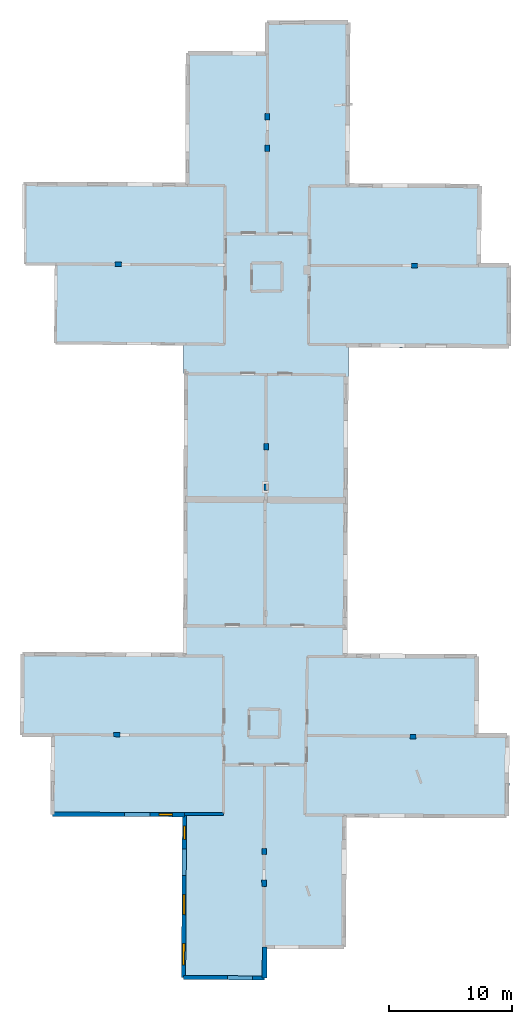
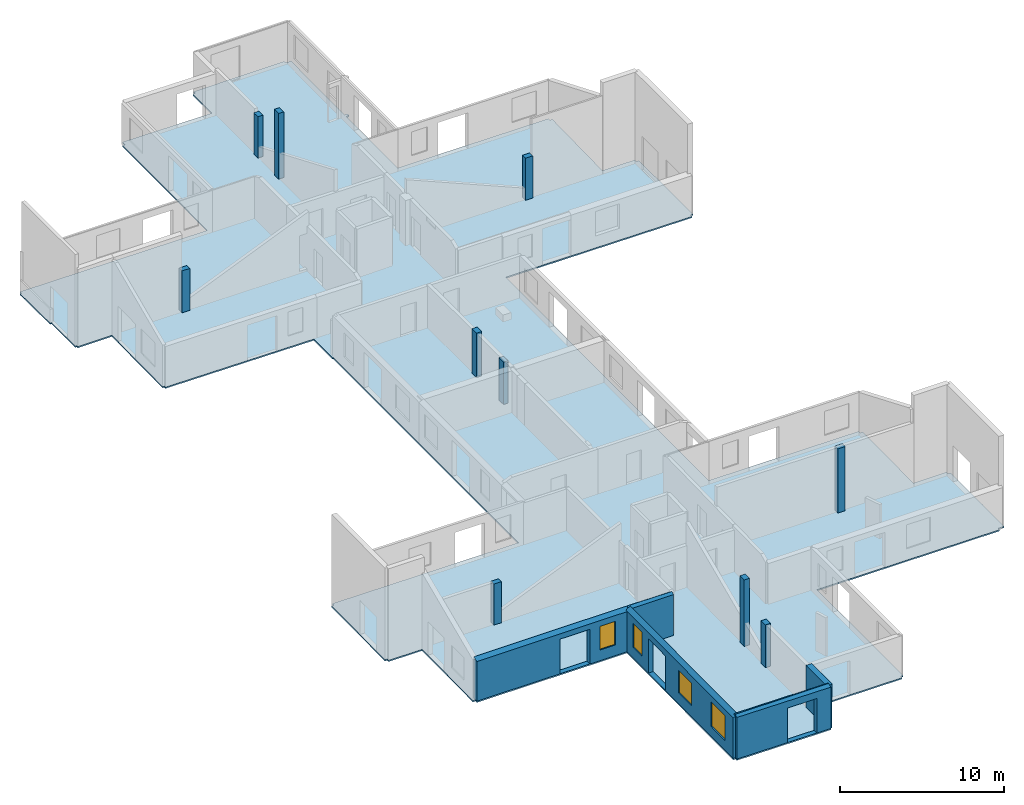
# One storey, part 1 of 10: 10 columns, 5 walls, 4 windows, 1 slab, 7 openings.
"""IFC2X3 building model written with IfcOpenShell, lengths in metres."""

from ifc_helpers import new_model, entity, si_unit, converted_unit, derived_unit, direction, frame, frame_2d, origin, origin_2d_with_axis, place, context, subcontext, project, spatial, polyline, rectangle, outline, extrude, clip, halfspace, source, transform, mapped, material, layer, layer_set, layer_usage, type_object, type_shapes, element, fill, save


model = new_model("IFC2X3")

# Units and contexts
model_context = context("Model", 3, precision=1e-05, world=origin(), true_north=direction((0.0, 1.0)))
body_context = subcontext(model_context, "Body", "Model", "MODEL_VIEW")
ifc_project = project(units=[si_unit("LENGTHUNIT", "METRE"), si_unit("AREAUNIT", "SQUARE_METRE"), si_unit("VOLUMEUNIT", "CUBIC_METRE"), converted_unit("PLANEANGLEUNIT", "DEGREE", entity("IfcRatioMeasure", 0.0174532925199433), si_unit("PLANEANGLEUNIT", "RADIAN"), dimensions=[0, 0, 0, 0, 0, 0, 0]), si_unit("MASSUNIT", "GRAM", prefix="KILO"), derived_unit("MASSDENSITYUNIT", [(si_unit("MASSUNIT", "GRAM", prefix="KILO"), 1), (si_unit("LENGTHUNIT", "METRE"), -3)]), derived_unit("MOMENTOFINERTIAUNIT", [(si_unit("LENGTHUNIT", "METRE"), 4)]), si_unit("TIMEUNIT", "SECOND"), si_unit("FREQUENCYUNIT", "HERTZ"), si_unit("THERMODYNAMICTEMPERATUREUNIT", "DEGREE_CELSIUS"), derived_unit("THERMALTRANSMITTANCEUNIT", [(si_unit("MASSUNIT", "GRAM", prefix="KILO"), 1), (si_unit("THERMODYNAMICTEMPERATUREUNIT", "KELVIN"), -1), (si_unit("TIMEUNIT", "SECOND"), -3)]), derived_unit("VOLUMETRICFLOWRATEUNIT", [(si_unit("LENGTHUNIT", "METRE"), 3), (si_unit("TIMEUNIT", "SECOND"), -1)]), si_unit("ELECTRICCURRENTUNIT", "AMPERE"), si_unit("ELECTRICVOLTAGEUNIT", "VOLT"), si_unit("POWERUNIT", "WATT"), si_unit("FORCEUNIT", "NEWTON", prefix="KILO"), si_unit("ILLUMINANCEUNIT", "LUX"), si_unit("LUMINOUSFLUXUNIT", "LUMEN"), si_unit("LUMINOUSINTENSITYUNIT", "CANDELA"), derived_unit("USERDEFINED", [(si_unit("MASSUNIT", "GRAM", prefix="KILO"), -1), (si_unit("LENGTHUNIT", "METRE"), -2), (si_unit("TIMEUNIT", "SECOND"), 3), (si_unit("LUMINOUSFLUXUNIT", "LUMEN"), 1)]), derived_unit("LINEARVELOCITYUNIT", [(si_unit("LENGTHUNIT", "METRE"), 1), (si_unit("TIMEUNIT", "SECOND"), -1)]), si_unit("PRESSUREUNIT", "PASCAL"), derived_unit("USERDEFINED", [(si_unit("LENGTHUNIT", "METRE"), -2), (si_unit("MASSUNIT", "GRAM", prefix="KILO"), 1), (si_unit("TIMEUNIT", "SECOND"), -2)]), derived_unit("LINEARFORCEUNIT", [(si_unit("MASSUNIT", "GRAM", prefix="KILO"), 1), (si_unit("LENGTHUNIT", "METRE"), 1), (si_unit("TIMEUNIT", "SECOND"), -2), (si_unit("LENGTHUNIT", "METRE"), -1)]), derived_unit("PLANARFORCEUNIT", [(si_unit("MASSUNIT", "GRAM", prefix="KILO"), 1), (si_unit("LENGTHUNIT", "METRE"), 1), (si_unit("TIMEUNIT", "SECOND"), -2), (si_unit("LENGTHUNIT", "METRE"), -2)])], contexts=[model_context])

# Site, building, storey
placement = place(None, origin())
site = spatial("IfcSite", under=ifc_project, at=placement, CompositionType="ELEMENT")
building = spatial("IfcBuilding", under=site, at=placement, CompositionType="ELEMENT")
storey_placement = place(placement, frame((0.0, 0.0, 15.2695512771606)))
storey = spatial("IfcBuildingStorey", under=building, at=storey_placement, Name="Level 6", CompositionType="ELEMENT", Elevation=15.2695512771606)

# Columns
ifc_material_1 = material()
column_type_1 = type_object("IfcColumnType", Name="Rectangular Column:555 x 310mm", PredefinedType="COLUMN", material=ifc_material_1)
shared_shape_1 = source(origin(), body_context, "Body", "SweptSolid", [
    extrude(rectangle(XDim=0.554955618167444, YDim=0.310000002384186, at=origin_2d_with_axis()), frame((0.0, 0.0, 0.0), z_axis=(0.0, 0.0, 1.0), x_axis=(0.0, -1.0, 0.0)), (0.0, 0.0, 1.0), 3.14399909973145),
])
type_shapes(column_type_1, [shared_shape_1])
column_1_placement = place(placement, frame((6.28059962989122, 39.5834904717086, 15.2700004577637), z_axis=(0.0, 0.0, 1.0), x_axis=(0.999998038736103, 0.00198053627772667, 0.0)))
element("IfcColumn", 1, at=column_1_placement, inside=storey, type_object=column_type_1, Name="Rectangular Column:555 x 310mm", ObjectType="Rectangular Column:555 x 310mm", context=body_context, shape_type="MappedRepresentation", body=[
    mapped(shared_shape_1, transform((0.0, 0.0, 0.0), scale=1.0)),
])
column_type_2 = type_object("IfcColumnType", Name="Rectangular Column:496 x 360mm", PredefinedType="COLUMN", material=ifc_material_1)
shared_shape_2 = source(origin(), body_context, "Body", "SweptSolid", [
    extrude(rectangle(XDim=0.495687838627537, YDim=0.360000014305115, at=origin_2d_with_axis()), frame((0.0, 0.0, 0.0), z_axis=(0.0, 0.0, 1.0), x_axis=(0.0, -1.0, 0.0)), (0.0, 0.0, 1.0), 3.07500076293945),
])
type_shapes(column_type_2, [shared_shape_2])
column_2_placement = place(placement, frame((6.42300283798488, 69.6784577781805, 15.2730007171631), z_axis=(0.0, 0.0, 1.0), x_axis=(-0.999987741803725, -0.00495138791516025, 0.0)))
element("IfcColumn", 2, at=column_2_placement, inside=storey, type_object=column_type_2, Name="Rectangular Column:496 x 360mm", ObjectType="Rectangular Column:496 x 360mm", context=body_context, shape_type="MappedRepresentation", body=[
    mapped(shared_shape_2, transform((0.0, 0.0, 0.0), scale=1.0)),
])
column_type_3 = type_object("IfcColumnType", Name="Rectangular Column:541 x 360mm", PredefinedType="COLUMN", material=ifc_material_1)
shared_shape_3 = source(origin(), body_context, "Body", "SweptSolid", [
    extrude(rectangle(XDim=0.540847853740699, YDim=0.360000014305115, at=origin_2d_with_axis()), frame((0.0, 0.0, 0.0), z_axis=(0.0, 0.0, 1.0), x_axis=(0.0, -1.0, 0.0)), (0.0, 0.0, 1.0), 3.30699920654297),
])
type_shapes(column_type_3, [shared_shape_3])
column_3_placement = place(placement, frame((6.31458798521526, 42.8700176879794, 15.2700004577637), z_axis=(0.0, 0.0, 1.0), x_axis=(-0.999999860578549, -0.000528055756389902, 0.0)))
element("IfcColumn", 3, at=column_3_placement, inside=storey, type_object=column_type_3, Name="Rectangular Column:541 x 360mm", ObjectType="Rectangular Column:541 x 360mm", context=body_context, shape_type="MappedRepresentation", body=[
    mapped(shared_shape_3, transform((0.0, 0.0, 0.0), scale=1.0)),
])
column_type_4 = type_object("IfcColumnType", Name="Rectangular Column:520 x 360mm", PredefinedType="COLUMN", material=ifc_material_1)
shared_shape_4 = source(origin(), body_context, "Body", "SweptSolid", [
    extrude(rectangle(XDim=0.519999906082088, YDim=0.360000014305115, at=origin_2d_with_axis()), frame((0.0, 0.0, 0.0), z_axis=(0.0, 0.0, 1.0), x_axis=(0.0, -1.0, 0.0)), (0.0, 0.0, 1.0), 3.04999923706055),
])
type_shapes(column_type_4, [shared_shape_4])
column_4_placement = place(placement, frame((-5.82657999178579, 19.4923216225972, 15.2700004577637), z_axis=(0.0, 0.0, 1.0), x_axis=(-0.0108205395384515, -0.999941456248363, 0.0)))
element("IfcColumn", 4, at=column_4_placement, inside=storey, type_object=column_type_4, Name="Rectangular Column:520 x 360mm", ObjectType="Rectangular Column:520 x 360mm", context=body_context, shape_type="MappedRepresentation", body=[
    mapped(shared_shape_4, transform((0.0, 0.0, 0.0), scale=1.0)),
])
column_type_5 = type_object("IfcColumnType", Name="Rectangular Column:530 x 370mm", PredefinedType="COLUMN", material=ifc_material_1)
shared_shape_5 = source(origin(), body_context, "Body", "SweptSolid", [
    extrude(rectangle(XDim=0.529999889638574, YDim=0.370000004768372, at=origin_2d_with_axis()), frame((0.0, 0.0, 0.0), z_axis=(0.0, 0.0, 1.0), x_axis=(0.0, -1.0, 0.0)), (0.0, 0.0, 1.0), 3.18000030517578),
])
type_shapes(column_type_5, [shared_shape_5])
column_5_placement = place(placement, frame((6.14692479751303, 7.39468000555512, 15.2709999084473), z_axis=(0.0, 0.0, 1.0), x_axis=(-0.999978111767537, -0.00661634233021978, 0.0)))
element("IfcColumn", 5, at=column_5_placement, inside=storey, type_object=column_type_5, Name="Rectangular Column:530 x 370mm", ObjectType="Rectangular Column:530 x 370mm", context=body_context, shape_type="MappedRepresentation", body=[
    mapped(shared_shape_5, transform((0.0, 0.0, 0.0), scale=1.0)),
])
column_type_6 = type_object("IfcColumnType", Name="Rectangular Column:547 x 360mm", PredefinedType="COLUMN", material=ifc_material_1)
shared_shape_6 = source(origin(), body_context, "Body", "SweptSolid", [
    extrude(rectangle(XDim=0.546929120389239, YDim=0.360000014305115, at=origin_2d_with_axis()), frame((0.0, 0.0, 0.0), z_axis=(0.0, 0.0, 1.0), x_axis=(0.0, -1.0, 0.0)), (0.0, 0.0, 1.0), 3.11999988555908),
])
type_shapes(column_type_6, [shared_shape_6])
column_6_placement = place(placement, frame((-5.69298660466509, 57.69110534655, 15.2720003128052), z_axis=(0.0, 0.0, 1.0), x_axis=(-0.00583001233721906, -0.999983005333665, 0.0)))
element("IfcColumn", 6, at=column_6_placement, inside=storey, type_object=column_type_6, Name="Rectangular Column:547 x 360mm", ObjectType="Rectangular Column:547 x 360mm", context=body_context, shape_type="MappedRepresentation", body=[
    mapped(shared_shape_6, transform((0.0, 0.0, 0.0), scale=1.0)),
])
column_type_7 = type_object("IfcColumnType", Name="Rectangular Column:508 x 360mm", PredefinedType="COLUMN", material=ifc_material_1)
shared_shape_7 = source(origin(), body_context, "Body", "SweptSolid", [
    extrude(rectangle(XDim=0.508020948419314, YDim=0.360000014305115, at=origin_2d_with_axis()), frame((0.0, 0.0, 0.0), z_axis=(0.0, 0.0, 1.0), x_axis=(0.0, -1.0, 0.0)), (0.0, 0.0, 1.0), 3.13500022888184),
])
type_shapes(column_type_7, [shared_shape_7])
column_7_placement = place(placement, frame((18.3760133682433, 57.5832851156591, 15.2709999084473), z_axis=(0.0, 0.0, 1.0), x_axis=(0.00311219086965767, -0.999995157122269, 0.0)))
element("IfcColumn", 7, at=column_7_placement, inside=storey, type_object=column_type_7, Name="Rectangular Column:508 x 360mm", ObjectType="Rectangular Column:508 x 360mm", context=body_context, shape_type="MappedRepresentation", body=[
    mapped(shared_shape_7, transform((0.0, 0.0, 0.0), scale=1.0)),
])
column_type_8 = type_object("IfcColumnType", Name="Rectangular Column:522 x 370mm", PredefinedType="COLUMN", material=ifc_material_1)
shared_shape_8 = source(origin(), body_context, "Body", "SweptSolid", [
    extrude(rectangle(XDim=0.521854917962663, YDim=0.370000004768372, at=origin_2d_with_axis()), frame((0.0, 0.0, 0.0), z_axis=(0.0, 0.0, 1.0), x_axis=(0.0, -1.0, 0.0)), (0.0, 0.0, 1.0), 4.9419994354248),
])
type_shapes(column_type_8, [shared_shape_8])
column_8_placement = place(placement, frame((6.15760957725205, 9.99132325099395, 15.2700004577637), z_axis=(0.0, 0.0, 1.0), x_axis=(-0.999999008058355, 0.00140850356977956, 0.0)))
element("IfcColumn", 8, at=column_8_placement, inside=storey, type_object=column_type_8, Name="Rectangular Column:522 x 370mm", ObjectType="Rectangular Column:522 x 370mm", context=body_context, shape_type="MappedRepresentation", body=[
    mapped(shared_shape_8, transform((0.0, 0.0, 0.0), scale=1.0)),
])
column_type_9 = type_object("IfcColumnType", Name="Rectangular Column:515 x 350mm", PredefinedType="COLUMN", material=ifc_material_1)
shared_shape_9 = source(origin(), body_context, "Body", "SweptSolid", [
    extrude(rectangle(XDim=0.514977418679187, YDim=0.349999994039536, at=origin_2d_with_axis()), frame((0.0, 0.0, 0.0), z_axis=(0.0, 0.0, 1.0), x_axis=(0.0, -1.0, 0.0)), (0.0, 0.0, 1.0), 4.77499961853027),
])
type_shapes(column_type_9, [shared_shape_9])
column_9_placement = place(placement, frame((18.2449601750627, 19.31607682049, 15.2700004577637), z_axis=(0.0, 0.0, 1.0), x_axis=(0.00507703230326486, 0.999987111788443, 0.0)))
element("IfcColumn", 9, at=column_9_placement, inside=storey, type_object=column_type_9, Name="Rectangular Column:515 x 350mm", ObjectType="Rectangular Column:515 x 350mm", context=body_context, shape_type="MappedRepresentation", body=[
    mapped(shared_shape_9, transform((0.0, 0.0, 0.0), scale=1.0)),
])
column_type_10 = type_object("IfcColumnType", Name="Rectangular Column:521 x 360mm", PredefinedType="COLUMN", material=ifc_material_1)
shared_shape_10 = source(origin(), body_context, "Body", "SweptSolid", [
    extrude(rectangle(XDim=0.520875613384302, YDim=0.360000014305115, at=origin_2d_with_axis()), frame((0.0, 0.0, 0.0), z_axis=(0.0, 0.0, 1.0), x_axis=(0.0, -1.0, 0.0)), (0.0, 0.0, 1.0), 4.875),
])
type_shapes(column_type_10, [shared_shape_10])
column_10_placement = place(placement, frame((6.4086052307025, 67.1315591320255, 15.2700004577637), z_axis=(0.0, 0.0, 1.0), x_axis=(0.999996948829874, 0.00247028964743017, 0.0)))
element("IfcColumn", 10, at=column_10_placement, inside=storey, type_object=column_type_10, Name="Rectangular Column:521 x 360mm", ObjectType="Rectangular Column:521 x 360mm", context=body_context, shape_type="MappedRepresentation", body=[
    mapped(shared_shape_10, transform((0.0, 0.0, 0.0), scale=1.0)),
])

# Slab
ifc_material_2 = material(Name="Floor default")
ifc_layer_1 = layer(ifc_material_2, 0.1)
ifc_layer_set_1 = layer_set([ifc_layer_1], Name="Floor : 100mm")
ifc_layer_usage_1 = layer_usage(ifc_layer_set_1, "AXIS3", "POSITIVE", 0.0)
slab_type = type_object("IfcSlabType", Name="Floor : 100mm", PredefinedType="FLOOR")
slab_placement = place(storey_placement, origin())
element("IfcSlab", 11, at=slab_placement, inside=storey, type_object=slab_type, material=ifc_layer_usage_1, Name="Floor : 100mm", ObjectType="Floor : 100mm", PredefinedType="FLOOR", context=body_context, shape_type="SweptSolid", body=[
    extrude(outline(polyline([(-13.6775064468384, 19.4523067474365), (-13.5125122070312, 19.4509353637695), (-13.5130367279053, 19.2809371948242), (-11.1665010452271, 19.2736930847168), (-11.2055521011353, 13.0168399810791), (-11.0355567932129, 13.0157794952393), (-11.0360441207886, 12.8407793045044), (-0.488040924072266, 12.8114242553711), (-0.560510635375977, -0.234981536865234), (-0.39051342010498, -0.23592583835125), (-0.391674995422363, -0.400919616222382), (6.187424659729, -0.447256088256836), (6.18858623504639, -0.282260447740555), (6.378586769104, -0.282702565193176), (6.38408756256104, 2.0816593170166), (12.6323537826538, 2.05682969093323), (12.6330099105835, 2.22182846069336), (12.8180074691772, 2.22156643867493), (12.8329019546509, 12.7412919998169), (25.6211280822754, 12.6943855285645), (25.621753692627, 12.8643856048584), (25.7205238342285, 12.8487644195557), (25.7229614257812, 12.8641748428345), (26.0473327636719, 12.862603187561), (26.0594863891602, 15.3704719543457), (26.073356628418, 15.3701572418213), (26.0778923034668, 15.570104598999), (26.0604591369629, 15.570499420166), (26.0790824890137, 19.4132404327393), (25.8940811157227, 19.4141368865967), (25.8935623168945, 19.6041355133057), (23.571849822998, 19.5977725982666), (23.6185340881348, 25.8382701873779), (23.433536529541, 25.8396549224854), (23.4343681335449, 26.0296535491943), (12.9072828292847, 26.075611114502), (12.9181966781616, 28.8485736846924), (12.9181966781616, 28.8485736846924), (12.9551687240601, 38.2405242919922), (12.9551687240601, 38.2405242919922), (12.9959058761597, 48.5895385742188), (12.9959058761597, 48.5895385742188), (13.0051546096802, 50.9392242431641), (26.0334396362305, 50.860466003418), (26.0345306396484, 51.0404586791992), (26.2195320129395, 51.0405426025391), (26.2165641784668, 57.6141510009766), (26.0315628051758, 57.6140670776367), (26.031665802002, 57.7990646362305), (23.7575378417969, 57.8003311157227), (23.8421325683594, 64.0422134399414), (23.6571502685547, 64.0447158813477), (23.6580848693848, 64.2247161865234), (13.0901136398315, 64.2796630859375), (13.1214551925659, 70.5778427124023), (13.3330945968628, 70.590705871582), (13.3209638595581, 70.7903366088867), (13.1224527359009, 70.7782745361328), (13.155177116394, 77.3534851074219), (12.7851819992065, 77.3553237915039), (12.780613899231, 77.5384521484375), (6.39149188995361, 77.5060806274414), (6.39242839813232, 77.3210830688477), (6.22243022918701, 77.3213958740234), (6.21812725067139, 74.9745025634766), (-0.0373563766479492, 75.0369415283203), (-0.0405387878417969, 74.7181015014648), (-0.209691047668457, 74.7187576293945), (-0.249942779541016, 64.3420333862305), (-13.38450050354, 64.3979949951172), (-13.3852672576904, 64.2179946899414), (-13.489670753479, 64.2181167602539), (-13.4895687103271, 64.1389999389648), (-13.484694480896, 64.1390075683594), (-13.458909034729, 60.5965881347656), (-13.3650093078613, 60.5972747802734), (-13.3612957000732, 57.7122192382812), (-13.2462949752808, 57.7123718261719), (-13.2454290390015, 57.5873794555664), (-10.8522958755493, 57.6039505004883), (-10.9068584442139, 51.3192901611328), (-10.791862487793, 51.3182907104492), (-10.7930183410645, 51.1932907104492), (-0.400027275085449, 51.0972442626953), (-0.410968780517578, 48.8029479980469), (-0.355249404907227, 48.8026809692383), (-0.390460014343262, 37.9739990234375), (-0.428905487060547, 26.1497611999512), (-13.4569463729858, 26.2134571075439), (-13.45787525177, 26.023458480835), (-13.6228685379028, 26.024829864502), (-13.6775064468384, 19.4523067474365)])), frame((0.0, 0.0, -0.1), z_axis=(0.0, 0.0, 1.0), x_axis=(1.0, 0.0, 0.0)), (0.0, 0.0, 1.0), 0.1),
])

# Wall
ifc_material_3 = material(Name="Default wall")
ifc_layer_2 = layer(ifc_material_3, 0.25)
ifc_layer_set_2 = layer_set([ifc_layer_2], Name="wall_thickness_0.2500")
ifc_layer_usage_2 = layer_usage(ifc_layer_set_2, "AXIS2", "POSITIVE", -0.125)
wall_type_1 = type_object("IfcWallType", Name="wall_thickness_0.2500", PredefinedType="STANDARD", material=ifc_layer_set_2)
wall_1_placement = place(storey_placement, frame((-0.316791542960335, 13.0359492373876, 0.0), z_axis=(0.0, 0.0, 1.0), x_axis=(0.999996127003023, -0.00278315988666487, 0.0)))
element("IfcWallStandardCase", 12, at=wall_1_placement, inside=storey, type_object=wall_type_1, material=ifc_layer_usage_2, Name="Wall:188", ObjectType="Wall", context=body_context, shape_type="Clipping", body=[
    clip(clip(extrude(outline(polyline([(3.15794379694518, -0.125), (3.15794379694518, 0.125), (0.0, 0.125), (0.0, -0.125), (3.15794379694518, -0.125)])), origin(), (0.0, 0.0, 1.0), 3.13044834136963), halfspace(frame((-11.7345132076666, 6.52534629958121, 5.79555813666937), z_axis=(-0.00321063470625789, -0.389128261697208, 0.921177989192801), x_axis=(0.999975201608374, -0.00702334423577843, 0.000518463148508191)), False)), halfspace(frame((-1.12080990615879, 62.8049780186927, 2.60439273833051), z_axis=(-0.389900634736588, 0.000329275097218849, 0.920856876289642), x_axis=(0.92085117875061, -0.00298413353263852, 0.389902810378011)), False)),
])

# Wall, opening
ifc_layer_3 = layer(ifc_material_3, 0.330000013113022)
ifc_layer_set_3 = layer_set([ifc_layer_3], Name="wall_thickness_0.3300")
ifc_layer_usage_3 = layer_usage(ifc_layer_set_3, "AXIS2", "POSITIVE", -0.165000006556511)
wall_type_2 = type_object("IfcWallType", Name="wall_thickness_0.3300", PredefinedType="STANDARD", material=ifc_layer_set_3)
wall_2_placement = place(storey_placement, frame((-0.390513409592262, -0.235923701806279, 0.0), z_axis=(0.0, 0.0, 1.0), x_axis=(0.99997519913753, -0.00704280553881451, 0.0)))
wall_2 = element("IfcWallStandardCase", 13, at=wall_2_placement, inside=storey, type_object=wall_type_2, material=ifc_layer_usage_3, Name="Wall:230", ObjectType="Wall", context=body_context, shape_type="Clipping", body=[
    clip(extrude(outline(polyline([(6.57926330339287, -0.165000006556511), (6.57926330339287, 0.165000006556511), (0.0, 0.165000006556511), (0.0, -0.165000006556511), (6.57926330339287, -0.165000006556511)])), origin(), (0.0, 0.0, 1.0), 3.19044971466064), halfspace(frame((-0.896439953111791, -1.12686146037605, 2.68738778709587), z_axis=(0.00267249054516933, -0.392735571235704, 0.919647556882772), x_axis=(0.999976848012874, 0.00680466297745467, 0.0)), False)),
])
opening_1_placement = place(wall_2_placement, frame((3.55674242545101, -0.165000006556511, 0.00544929504394531)))
element("IfcOpeningElement", 14, at=opening_1_placement, cuts=wall_2, Name="Opening : 2045 x 2565 : 204", ObjectType="Opening", context=body_context, shape_type="SweptSolid", body=[
    extrude(rectangle(XDim=2.045, YDim=2.565, at=frame_2d((1.2825, 1.0225), x_axis=(0.0, 1.0))), frame((0.0, 0.0, 0.0), z_axis=(0.0, 1.0, 0.0), x_axis=(0.0, 0.0, 1.0)), (0.0, 0.0, 1.0), 0.330000013113022),
])

# Wall, openings, window
ifc_layer_4 = layer(ifc_material_3, 0.349999994039536)
ifc_layer_set_4 = layer_set([ifc_layer_4], Name="wall_thickness_0.3500")
ifc_layer_usage_4 = layer_usage(ifc_layer_set_4, "AXIS2", "POSITIVE", -0.174999997019768)
wall_type_3 = type_object("IfcWallType", Name="wall_thickness_0.3500", PredefinedType="STANDARD", material=ifc_layer_set_4)
wall_3_placement = place(storey_placement, frame((-11.0355574169648, 13.0157784592262, 0.0), z_axis=(0.0, 0.0, 1.0), x_axis=(0.999996127615628, -0.00278293976751727, 0.0)))
wall_3 = element("IfcWallStandardCase", 15, at=wall_3_placement, inside=storey, type_object=wall_type_3, material=ifc_layer_usage_4, Name="Wall:187", ObjectType="Wall", context=body_context, shape_type="Clipping", body=[
    clip(extrude(outline(polyline([(10.7185306763451, -0.174999997019768), (10.7185306763451, 0.174999997019768), (0.0, 0.174999997019768), (0.0, -0.174999997019768), (10.7185306763451, -0.174999997019768)])), origin(), (0.0, 0.0, 1.0), 3.13044834136963), halfspace(frame((-1.01584353854483, 6.57534926244399, 5.79555813666937), z_axis=(-0.0032107203611708, -0.389128260990474, 0.921177989192801), x_axis=(0.999975200062372, -0.0070235643503197, 0.000518463148508191)), False)),
])
opening_2_placement = place(wall_3_placement, frame((5.82957425321789, -0.174999997019768, 0.00544929504394531)))
element("IfcOpeningElement", 16, at=opening_2_placement, cuts=wall_3, Name="Opening : 2105 x 2575 : 166", ObjectType="Opening", context=body_context, shape_type="SweptSolid", body=[
    extrude(rectangle(XDim=2.105, YDim=2.575, at=frame_2d((1.2875, 1.0525), x_axis=(0.0, 1.0))), frame((0.0, 0.0, 0.0), z_axis=(0.0, 1.0, 0.0), x_axis=(0.0, 0.0, 1.0)), (0.0, 0.0, 1.0), 0.349999994039536),
])
opening_3_placement = place(wall_3_placement, frame((8.64957485429342, -0.174999997019768, 0.790450096130371)))
opening_3 = element("IfcOpeningElement", 17, at=opening_3_placement, cuts=wall_3, Name="Opening : 1085 x 1760 : 167", ObjectType="Opening", context=body_context, shape_type="SweptSolid", body=[
    extrude(rectangle(XDim=1.085, YDim=1.76, at=frame_2d((0.88, 0.5425), x_axis=(0.0, 1.0))), frame((0.0, 0.0, 0.0), z_axis=(0.0, 1.0, 0.0), x_axis=(0.0, 0.0, 1.0)), (0.0, 0.0, 1.0), 0.349999994039536),
])
ifc_material_4 = material(Name="Window Default")
window_style_1 = type_object("IfcWindowStyle", Name="Window : 1085 x 1760mm", ConstructionType="NOTDEFINED", OperationType="NOTDEFINED", ParameterTakesPrecedence=False, Sizeable=False, material=ifc_material_4)
shared_shape_11 = source(origin(), body_context, "Body", "SweptSolid", [
    extrude(rectangle(XDim=0.174999997019768, YDim=1.085, at=origin_2d_with_axis()), frame((0.5425, 0.174999997019768, 0.0), z_axis=(0.0, 0.0, 1.0), x_axis=(0.0, 1.0, 0.0)), (0.0, 0.0, 1.0), 1.76),
])
type_shapes(window_style_1, [shared_shape_11])
window_1_placement = place(opening_3_placement, origin())
window_1 = element("IfcWindow", 18, at=window_1_placement, inside=storey, type_object=window_style_1, Name="Window : 1085 x 1760mm : 91", ObjectType="Window : 1085 x 1760mm", OverallHeight=1.76, OverallWidth=1.085, context=body_context, shape_type="MappedRepresentation", body=[
    mapped(shared_shape_11, transform((0.0, 0.0, 0.0), scale=1.0)),
])
fill(opening_3, window_1)

# Wall
ifc_layer_5 = layer(ifc_material_3, 0.379999995231628)
ifc_layer_set_5 = layer_set([ifc_layer_5], Name="wall_thickness_0.3800")
ifc_layer_usage_5 = layer_usage(ifc_layer_set_5, "AXIS2", "POSITIVE", -0.189999997615814)
wall_type_4 = type_object("IfcWallType", Name="wall_thickness_0.3800", PredefinedType="STANDARD", material=ifc_layer_set_5)
wall_4_placement = place(storey_placement, frame((6.19447384060531, 2.24741515918756, 0.0), z_axis=(0.0, 0.0, 1.0), x_axis=(-0.00232718203351948, -0.999997292108225, 0.0)))
element("IfcWallStandardCase", 19, at=wall_4_placement, inside=storey, type_object=wall_type_4, material=ifc_layer_usage_5, Name="Wall:210", ObjectType="Wall", context=body_context, shape_type="Clipping", body=[
    clip(extrude(outline(polyline([(2.52968245301921, -0.189999997615814), (2.52968245301921, 0.189999997615814), (0.0, 0.189999997615814), (0.0, -0.189999997615814), (2.52968245301921, -0.189999997615814)])), origin(), (0.0, 0.0, 1.0), 3.13044834136963), halfspace(frame((3.62127822347642, -7.48093412089991, 2.68738778709587), z_axis=(0.392743807051292, 0.000820452561953108, 0.919647556882772), x_axis=(-0.00208903434447929, 0.999997817965373, 0.0)), False)),
])

# Wall, openings, windows
ifc_layer_6 = layer(ifc_material_3, 0.340000003576279)
ifc_layer_set_6 = layer_set([ifc_layer_6], Name="wall_thickness_0.3400")
ifc_layer_usage_6 = layer_usage(ifc_layer_set_6, "AXIS2", "POSITIVE", -0.170000001788139)
wall_type_5 = type_object("IfcWallType", Name="wall_thickness_0.3400", PredefinedType="STANDARD", material=ifc_layer_set_6)
wall_5_placement = place(storey_placement, frame((-0.317069068576201, 12.9859512693335, 0.0), z_axis=(0.0, 0.0, 1.0), x_axis=(-0.00555465721337568, -0.999984572772621, 0.0)))
wall_5 = element("IfcWallStandardCase", 20, at=wall_5_placement, inside=storey, type_object=wall_type_5, material=ifc_layer_usage_6, Name="Wall:146", ObjectType="Wall", context=body_context, shape_type="Clipping", body=[
    clip(extrude(outline(polyline([(13.2220810781347, -0.170000001788139), (13.2220810781347, 0.170000001788139), (0.0, 0.170000001788139), (0.0, -0.170000001788139), (13.2220810781347, -0.170000001788139)])), origin(), (0.0, 0.0, 1.0), 3.19044971466064), halfspace(frame((-62.8516291983963, -1.2948709759133, 2.60439273833051), z_axis=(0.000751343087218411, -0.389900049850791, 0.920856876289642), x_axis=(0.000431965763731867, 0.920855912651327, 0.389902810378011)), False)),
])
opening_4_placement = place(wall_5_placement, frame((2.79450626907335, -0.170000001788139, 0.00544929504394531)))
element("IfcOpeningElement", 21, at=opening_4_placement, cuts=wall_5, Name="Opening : 2140 x 2560 : 137", ObjectType="Opening", context=body_context, shape_type="SweptSolid", body=[
    extrude(rectangle(XDim=2.14, YDim=2.56, at=frame_2d((1.28, 1.07), x_axis=(0.0, 1.0))), frame((0.0, 0.0, 0.0), z_axis=(0.0, 1.0, 0.0), x_axis=(0.0, 0.0, 1.0)), (0.0, 0.0, 1.0), 0.340000003576279),
])
opening_5_placement = place(wall_5_placement, frame((10.4845055139596, -0.170000001788139, 0.730448722839355)))
opening_5 = element("IfcOpeningElement", 22, at=opening_5_placement, cuts=wall_5, Name="Opening : 1725 x 1855 : 138", ObjectType="Opening", context=body_context, shape_type="SweptSolid", body=[
    extrude(rectangle(XDim=1.725, YDim=1.855, at=frame_2d((0.9275, 0.8625), x_axis=(0.0, 1.0))), frame((0.0, 0.0, 0.0), z_axis=(0.0, 1.0, 0.0), x_axis=(0.0, 0.0, 1.0)), (0.0, 0.0, 1.0), 0.340000003576279),
])
opening_6_placement = place(wall_5_placement, frame((0.904506332287225, -0.170000001788139, 0.780449867248535)))
opening_6 = element("IfcOpeningElement", 23, at=opening_6_placement, cuts=wall_5, Name="Opening : 1095 x 1780 : 139", ObjectType="Opening", context=body_context, shape_type="SweptSolid", body=[
    extrude(rectangle(XDim=1.095, YDim=1.78, at=frame_2d((0.89, 0.5475), x_axis=(0.0, 1.0))), frame((0.0, 0.0, 0.0), z_axis=(0.0, 1.0, 0.0), x_axis=(0.0, 0.0, 1.0)), (0.0, 0.0, 1.0), 0.340000003576279),
])
opening_7_placement = place(wall_5_placement, frame((6.50241249750385, -0.170000001788139, 0.795449256896973)))
opening_7 = element("IfcOpeningElement", 24, at=opening_7_placement, cuts=wall_5, Name="Opening : 1630 x 1690 : 140", ObjectType="Opening", context=body_context, shape_type="SweptSolid", body=[
    extrude(rectangle(XDim=1.63, YDim=1.69, at=frame_2d((0.845, 0.815), x_axis=(0.0, 1.0))), frame((0.0, 0.0, 0.0), z_axis=(0.0, 1.0, 0.0), x_axis=(0.0, 0.0, 1.0)), (0.0, 0.0, 1.0), 0.340000003576279),
])
window_style_2 = type_object("IfcWindowStyle", Name="Window : 1725 x 1855mm", ConstructionType="NOTDEFINED", OperationType="NOTDEFINED", ParameterTakesPrecedence=False, Sizeable=False, material=ifc_material_4)
shared_shape_12 = source(origin(), body_context, "Body", "SweptSolid", [
    extrude(rectangle(XDim=0.170000001788139, YDim=1.725, at=origin_2d_with_axis()), frame((0.8625, 0.170000001788139, 0.0), z_axis=(0.0, 0.0, 1.0), x_axis=(0.0, 1.0, 0.0)), (0.0, 0.0, 1.0), 1.855),
])
type_shapes(window_style_2, [shared_shape_12])
window_2_placement = place(opening_5_placement, origin())
window_2 = element("IfcWindow", 25, at=window_2_placement, inside=storey, type_object=window_style_2, Name="Window : 1725 x 1855mm : 78", ObjectType="Window : 1725 x 1855mm", OverallHeight=1.855, OverallWidth=1.725, context=body_context, shape_type="MappedRepresentation", body=[
    mapped(shared_shape_12, transform((0.0, 0.0, 0.0), scale=1.0)),
])
fill(opening_5, window_2)
window_style_3 = type_object("IfcWindowStyle", Name="Window : 1095 x 1780mm", ConstructionType="NOTDEFINED", OperationType="NOTDEFINED", ParameterTakesPrecedence=False, Sizeable=False, material=ifc_material_4)
shared_shape_13 = source(origin(), body_context, "Body", "SweptSolid", [
    extrude(rectangle(XDim=0.170000001788139, YDim=1.095, at=origin_2d_with_axis()), frame((0.5475, 0.170000001788139, 0.0), z_axis=(0.0, 0.0, 1.0), x_axis=(0.0, 1.0, 0.0)), (0.0, 0.0, 1.0), 1.78),
])
type_shapes(window_style_3, [shared_shape_13])
window_3_placement = place(opening_6_placement, origin())
window_3 = element("IfcWindow", 26, at=window_3_placement, inside=storey, type_object=window_style_3, Name="Window : 1095 x 1780mm : 79", ObjectType="Window : 1095 x 1780mm", OverallHeight=1.78, OverallWidth=1.095, context=body_context, shape_type="MappedRepresentation", body=[
    mapped(shared_shape_13, transform((0.0, 0.0, 0.0), scale=1.0)),
])
fill(opening_6, window_3)
window_style_4 = type_object("IfcWindowStyle", Name="Window : 1630 x 1690mm", ConstructionType="NOTDEFINED", OperationType="NOTDEFINED", ParameterTakesPrecedence=False, Sizeable=False, material=ifc_material_4)
shared_shape_14 = source(origin(), body_context, "Body", "SweptSolid", [
    extrude(rectangle(XDim=0.170000001788139, YDim=1.63, at=origin_2d_with_axis()), frame((0.815, 0.170000001788139, 0.0), z_axis=(0.0, 0.0, 1.0), x_axis=(0.0, 1.0, 0.0)), (0.0, 0.0, 1.0), 1.69),
])
type_shapes(window_style_4, [shared_shape_14])
window_4_placement = place(opening_7_placement, origin())
window_4 = element("IfcWindow", 27, at=window_4_placement, inside=storey, type_object=window_style_4, Name="Window : 1630 x 1690mm : 80", ObjectType="Window : 1630 x 1690mm", OverallHeight=1.69, OverallWidth=1.63, context=body_context, shape_type="MappedRepresentation", body=[
    mapped(shared_shape_14, transform((0.0, 0.0, 0.0), scale=1.0)),
])
fill(opening_7, window_4)

save(model, "model.ifc")
